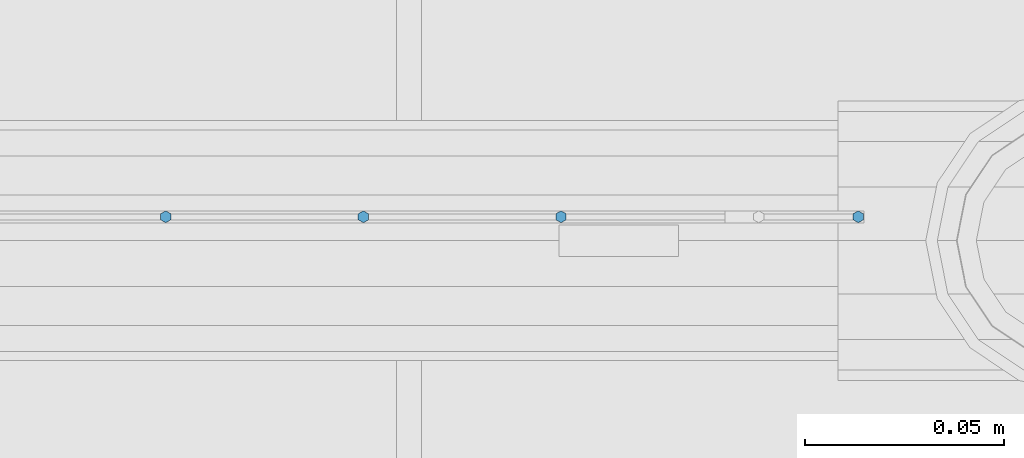
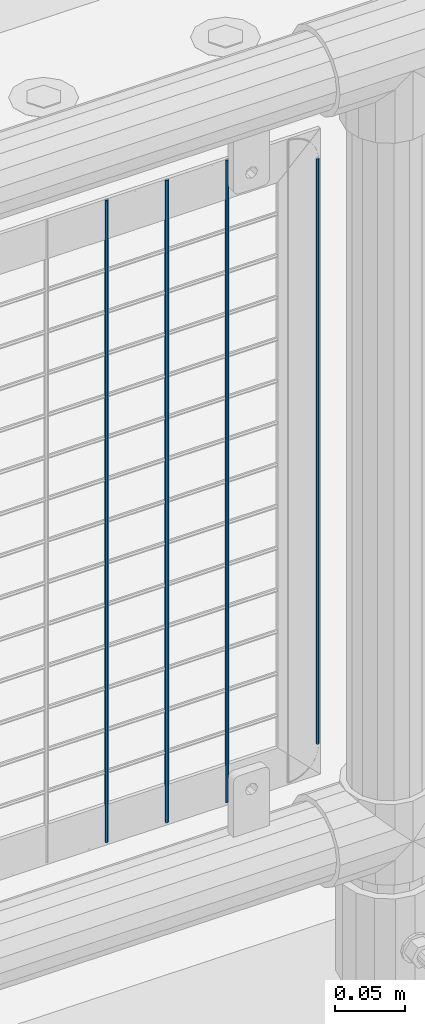
# One storey, part 73 of 247: 4 columns.
"""IFC2X3 building model written with IfcOpenShell, lengths in millimetres."""

from ifc_helpers import new_model, si_unit, frame, origin_with_axes, place, context, subcontext, project, spatial, faceted_brep, material, type_object, element, save


model = new_model("IFC2X3")

# Units and contexts
model_context = context("Model", 3, precision=1e-05, world=origin_with_axes())
body_context = subcontext(model_context, "Body", "Model", "MODEL_VIEW")
ifc_project = project(units=[si_unit("LENGTHUNIT", "METRE", prefix="MILLI"), si_unit("AREAUNIT", "SQUARE_METRE"), si_unit("VOLUMEUNIT", "CUBIC_METRE"), si_unit("MASSUNIT", "GRAM", prefix="KILO"), si_unit("TIMEUNIT", "SECOND"), si_unit("PLANEANGLEUNIT", "RADIAN"), si_unit("SOLIDANGLEUNIT", "STERADIAN"), si_unit("THERMODYNAMICTEMPERATUREUNIT", "DEGREE_CELSIUS"), si_unit("LUMINOUSINTENSITYUNIT", "LUMEN")], contexts=[model_context])

# Site, building, storey
site_placement = place(None, origin_with_axes())
site = spatial("IfcSite", under=ifc_project, at=site_placement, CompositionType="ELEMENT")
building_placement = place(site_placement, origin_with_axes())
building = spatial("IfcBuilding", under=site, at=building_placement, Name="Standard", CompositionType="ELEMENT")
storey_placement = place(building_placement, origin_with_axes())
storey = spatial("IfcBuildingStorey", under=building, at=storey_placement, Name="Undefined", CompositionType="ELEMENT", Elevation=0.0)

# Columns
ifc_material = material(Name="Misc_Undefined")
column_type = type_object("IfcColumnType", Name="D3", PredefinedType="NOTDEFINED")
for number, where, z_axis, x_axis in (
    (1, (2091.34, 7670.5, 353.02), (-1.0, 0.0, 0.0), (0.0, 0.0, 1.0)),
    (2, (2041.685, 7670.5, 353.02), (-1.0, 0.0, 0.0), (0.0, 0.0, 1.0)),
    (3, (1992.03, 7670.5, 353.02), (-1.0, 0.0, 0.0), (0.0, 0.0, 1.0)),
):
    element("IfcColumn", number, at=place(storey_placement, frame(where, z_axis=z_axis, x_axis=x_axis)), inside=storey, type_object=column_type, material=ifc_material, ObjectType="D3", context=body_context, shape_type="Brep", body=[
        faceted_brep([(1.81898940354586e-12, -1.5, -5.6843418860808e-14), (0.0, -0.75, -1.29903810567703), (560.0, -0.75, -1.29903810567703), (560.0, -1.5, 0.0), (0.0, 0.75, -1.29903810567703), (560.0, 0.75, -1.29903810567703), (1.81898940354586e-12, 1.5, -5.6843418860808e-14), (560.0, 1.5, 0.0), (0.0, 0.75, 1.29903810567703), (560.0, 0.75, 1.29903810567703), (0.0, -0.75, 1.29903810567703), (560.0, -0.75, 1.29903810567703)], [[[0, 1, 2, 3]], [[1, 4, 5, 2]], [[4, 6, 7, 5]], [[6, 8, 9, 7]], [[8, 10, 11, 9]], [[10, 0, 3, 11]], [[5, 7, 9, 11, 3, 2]], [[10, 8, 6, 4, 1, 0]]]),
    ])
column_placement = place(storey_placement, frame((2166.0, 7670.5, 378.02), z_axis=(-1.0, 0.0, 0.0), x_axis=(0.0, 0.0, 1.0)))
element("IfcColumn", 4, at=column_placement, inside=storey, type_object=column_type, material=ifc_material, ObjectType="D3", context=body_context, shape_type="Brep", body=[
    faceted_brep([(1.81898940354586e-12, -1.5, -5.6843418860808e-14), (0.0, -0.75, -1.29903810567703), (510.0, -0.75, -1.29903810567703), (510.0, -1.5, 0.0), (0.0, 0.75, -1.29903810567703), (510.0, 0.75, -1.29903810567703), (1.81898940354586e-12, 1.5, -5.6843418860808e-14), (510.0, 1.5, 0.0), (0.0, 0.75, 1.29903810567703), (510.0, 0.75, 1.29903810567703), (0.0, -0.75, 1.29903810567703), (510.0, -0.75, 1.29903810567703)], [[[0, 1, 2, 3]], [[1, 4, 5, 2]], [[4, 6, 7, 5]], [[6, 8, 9, 7]], [[8, 10, 11, 9]], [[10, 0, 3, 11]], [[5, 7, 9, 11, 3, 2]], [[10, 8, 6, 4, 1, 0]]]),
])

save(model, "model.ifc")
